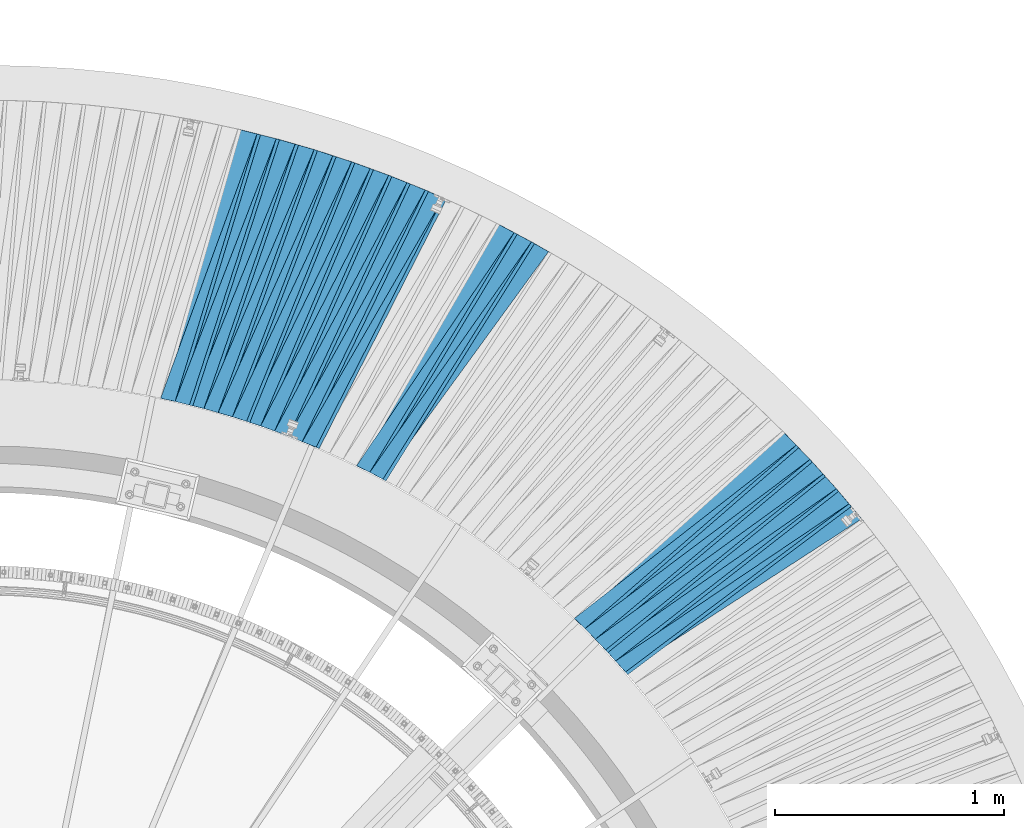
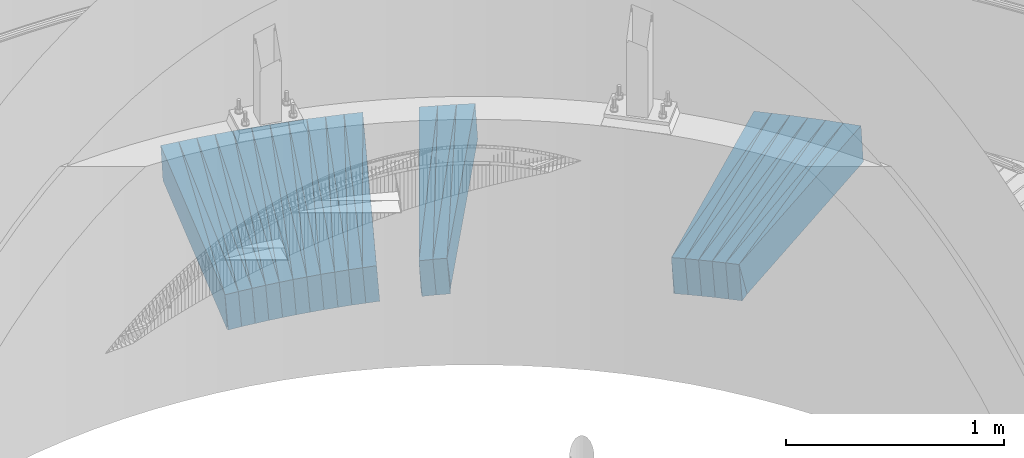
# One storey, part 840 of 975: 38 plates.
"""IFC2X3 building model written with IfcOpenShell, lengths in millimetres."""

from ifc_helpers import new_model, si_unit, frame, origin_with_axes, place, context, subcontext, project, spatial, faceted_brep, material, type_object, element, save


model = new_model("IFC2X3")

# Units and contexts
model_context = context("Model", 3, precision=1e-05, world=origin_with_axes())
body_context = subcontext(model_context, "Body", "Model", "MODEL_VIEW")
ifc_project = project(units=[si_unit("LENGTHUNIT", "METRE", prefix="MILLI"), si_unit("AREAUNIT", "SQUARE_METRE"), si_unit("VOLUMEUNIT", "CUBIC_METRE"), si_unit("MASSUNIT", "GRAM", prefix="KILO"), si_unit("TIMEUNIT", "SECOND"), si_unit("PLANEANGLEUNIT", "RADIAN"), si_unit("SOLIDANGLEUNIT", "STERADIAN"), si_unit("THERMODYNAMICTEMPERATUREUNIT", "DEGREE_CELSIUS"), si_unit("LUMINOUSINTENSITYUNIT", "LUMEN")], contexts=[model_context])

# Site, building, storey
site_placement = place(None, origin_with_axes())
site = spatial("IfcSite", under=ifc_project, at=site_placement, CompositionType="ELEMENT")
building_placement = place(site_placement, origin_with_axes())
building = spatial("IfcBuilding", under=site, at=building_placement, Name="Undefined", CompositionType="ELEMENT")
storey_placement = place(building_placement, origin_with_axes())
storey = spatial("IfcBuildingStorey", under=building, at=storey_placement, Name="Undefined", CompositionType="ELEMENT", Elevation=0.0)

# Plates
ifc_material = material(Name="STEEL/A36")
plate_type_1 = type_object("IfcPlateType", PredefinedType="NOTDEFINED")
plate_1_placement = place(storey_placement, frame((38512.4438444185, 6566.22397296083, 262.383749104979), z_axis=(0.600129765585182, -0.79788857567362, 0.0567281699704557), x_axis=(-0.799028901818095, -0.601278668863115, -0.00409590399906753)))
element("IfcPlate", 1, at=plate_1_placement, inside=storey, type_object=plate_type_1, material=ifc_material, Name="SLAB", context=body_context, shape_type="Brep", body=[
    faceted_brep([(-6.82121026329696e-12, -100.000000000011, -1.09139364212751e-10), (-4.58210372878966, -100.000000000019, 86.0459976193342), (-4.58210372927715, 99.999999999996, 86.0459976196398), (5.91171556152403e-12, 100.000000000011, 1.09139364212751e-10), (1220.7318115256, -100.000000000048, -9.56788426265121e-10), (1220.73181152511, 99.9999999999667, -6.51198206469417e-10)], [[[0, 1, 2, 3]], [[1, 4, 5, 2]], [[4, 0, 3, 5]], [[5, 3, 2]], [[4, 1, 0]]]),
])
plate_2_placement = place(storey_placement, frame((38457.2910185286, 6632.096490839, 257.390551568822), z_axis=(0.613989457399229, -0.787186763650281, 0.0579132570004221), x_axis=(-0.788357584905775, -0.615203687926472, -0.00409153799951098)))
element("IfcPlate", 2, at=plate_2_placement, inside=storey, type_object=plate_type_1, material=ifc_material, Name="SLAB", context=body_context, shape_type="Brep", body=[
    faceted_brep([(-6.82121026329696e-12, -100.000000000011, -1.09139364212751e-10), (-3.07470917727915, -99.9999999999881, 86.1187896730917), (-3.07470917695173, 99.9999999999933, 86.1187896727861), (5.91171556152403e-12, 100.000000000011, 1.09139364212751e-10), (1222.03430175661, -99.9999999999401, -9.1313268058002e-10), (1222.03430175695, 100.000000000041, -1.21872290037572e-09)], [[[0, 1, 2, 3]], [[1, 4, 5, 2]], [[4, 0, 3, 5]], [[5, 3, 2]], [[4, 1, 0]]]),
])
plate_3_placement = place(storey_placement, frame((38399.8665806011, 6696.06321003263, 252.390659540913), z_axis=(0.627521709639789, -0.776440877317488, 0.0579315799992184), x_axis=(-0.777591125053215, -0.62875692304303, -0.0040956030002803)))
element("IfcPlate", 3, at=plate_3_placement, inside=storey, type_object=plate_type_1, material=ifc_material, Name="SLAB", context=body_context, shape_type="Brep", body=[
    faceted_brep([(-6.82121026329696e-12, -100.000000000011, -1.09139364212751e-10), (-4.55440044427814, -99.9999999999895, 85.9867248536757), (-4.55440044394345, 99.9999999999973, 85.9867248534465), (5.91171556152403e-12, 100.000000000011, 1.09139364212751e-10), (1220.82153319966, -99.9999999998645, 4.24915924668312e-09), (1220.8215332, 100.000000000122, 4.01996658183634e-09)], [[[0, 1, 2, 3]], [[1, 4, 5, 2]], [[4, 0, 3, 5]], [[5, 3, 2]], [[4, 1, 0]]]),
])
plate_4_placement = place(storey_placement, frame((38342.3328437404, 6760.02912780385, 247.39052735229), z_axis=(0.641050823748855, -0.765310209783112, 0.057914800980785), x_axis=(-0.766441367156264, -0.642301761130953, -0.00400978300081753)))
element("IfcPlate", 4, at=plate_4_placement, inside=storey, type_object=plate_type_1, material=ifc_material, Name="SLAB", context=body_context, shape_type="Brep", body=[
    faceted_brep([(-6.82121026329696e-12, -100.000000000011, -1.09139364212751e-10), (-3.12398910509364, -100.000000000008, 86.1174240111322), (-3.12398910500633, 99.9999999999858, 86.1174240110013), (5.91171556152403e-12, 100.000000000011, 1.09139364212751e-10), (1222.01123047105, -100.000000000169, -5.89352566748857e-10), (1222.01123047113, 99.9999999998255, -7.20319803804159e-10)], [[[0, 1, 2, 3]], [[1, 4, 5, 2]], [[4, 0, 3, 5]], [[5, 3, 2]], [[4, 1, 0]]]),
])
plate_5_placement = place(storey_placement, frame((38282.5322403344, 6822.09727643282, 242.483601375224), z_axis=(0.654358193312262, -0.754055846141744, 0.0567021670182908), x_axis=(-0.755112156361949, -0.655582836314243, -0.00409585700196327)))
element("IfcPlate", 5, at=plate_5_placement, inside=storey, type_object=plate_type_1, material=ifc_material, Name="SLAB", context=body_context, shape_type="Brep", body=[
    faceted_brep([(-6.82121026329696e-12, -100.000000000011, -1.09139364212751e-10), (-4.59519910850213, -99.9999999999834, 86.0845184329119), (-4.59519910808012, 99.9999999999948, 86.0845184325372), (5.91171556152403e-12, 100.000000000011, 1.09139364212751e-10), (1220.74584960676, -99.9999999998415, 8.51287040859461e-10), (1220.74584960718, 100.000000000137, 4.76575223729014e-10)], [[[0, 1, 2, 3]], [[1, 4, 5, 2]], [[4, 0, 3, 5]], [[5, 3, 2]], [[4, 1, 0]]]),
])
plate_6_placement = place(storey_placement, frame((38222.9871864841, 6883.87299197705, 237.490949568583), z_axis=(0.667419123804655, -0.74242159243685, 0.0579818270094881), x_axis=(-0.743507605194825, -0.668714962175227, -0.00409150100107212)))
element("IfcPlate", 6, at=plate_6_placement, inside=storey, type_object=plate_type_1, material=ifc_material, Name="SLAB", context=body_context, shape_type="Brep", body=[
    faceted_brep([(-6.82121026329696e-12, -100.000000000011, -1.09139364212751e-10), (-3.08127689365938, -100.0, 86.0164871215857), (-3.08127689368848, 100.000000000003, 86.0164871216039), (5.91171556152403e-12, 100.000000000011, 1.09139364212751e-10), (1222.04528808264, -99.9999999998392, -1.78260961547494e-10), (1222.04528808261, 100.000000000164, -1.60071067512035e-10)], [[[0, 1, 2, 3]], [[1, 4, 5, 2]], [[4, 0, 3, 5]], [[5, 3, 2]], [[4, 1, 0]]]),
])
plate_7_placement = place(storey_placement, frame((37128.5289780376, 7710.67831532794, 158.090572427151), z_axis=(0.846231007963166, -0.529658433771036, 0.0579225750192148), x_axis=(-0.530347702982539, -0.847770744972089, -0.00400972699986798)))
element("IfcPlate", 7, at=plate_7_placement, inside=storey, type_object=plate_type_1, material=ifc_material, Name="SLAB", context=body_context, shape_type="Brep", body=[
    faceted_brep([(-6.82121026329696e-12, -100.000000000011, -1.09139364212751e-10), (-3.07681036011127, -99.9999999999825, 86.1091384890351), (-3.07681035977294, 99.9999999999834, 86.1091384884894), (5.91171556152403e-12, 100.000000000011, 1.09139364212751e-10), (1222.02844238158, -99.9999999998959, 2.1937012206763e-09), (1222.02844238191, 100.00000000007, 1.64436642080545e-09)], [[[0, 1, 2, 3]], [[1, 4, 5, 2]], [[4, 0, 3, 5]], [[5, 3, 2]], [[4, 1, 0]]]),
])
plate_8_placement = place(storey_placement, frame((37052.5827890472, 7751.13314609902, 153.184095133322), z_axis=(0.855317255811737, -0.514982910928696, 0.0567890250144053), x_axis=(-0.51561139213053, -0.856812765216909, -0.00409605500103695)))
element("IfcPlate", 8, at=plate_8_placement, inside=storey, type_object=plate_type_1, material=ifc_material, Name="SLAB", context=body_context, shape_type="Brep", body=[
    faceted_brep([(-6.82121026329696e-12, -100.000000000011, -1.09139364212751e-10), (-4.62542104727254, -99.999999999992, 85.9506607057083), (-4.62542104697059, 99.9999999999732, 85.9506607051153), (5.91171556152403e-12, 100.000000000011, 1.09139364212751e-10), (1220.68676757962, -100.000000000126, -3.31056071445346e-09), (1220.68676757992, 99.9999999998395, -3.90355126000941e-09)], [[[0, 1, 2, 3]], [[1, 4, 5, 2]], [[4, 0, 3, 5]], [[5, 3, 2]], [[4, 1, 0]]]),
])
plate_9_placement = place(storey_placement, frame((36976.8269970994, 7791.56415099977, 148.190736685674), z_axis=(0.86414602296163, -0.499893995993658, 0.0579451789978317), x_axis=(-0.50052559080456, -0.865712073661961, -0.00409126699840245)))
element("IfcPlate", 9, at=plate_9_placement, inside=storey, type_object=plate_type_1, material=ifc_material, Name="SLAB", context=body_context, shape_type="Brep", body=[
    faceted_brep([(-6.82121026329696e-12, -100.000000000011, -1.09139364212751e-10), (-3.03558087353667, -99.9999999999977, 86.0741271973347), (-3.0355808736058, 100.000000000005, 86.074127197342), (5.91171556152403e-12, 100.000000000011, 1.09139364212751e-10), (1222.11535644437, -99.9999999999347, -7.38509697839618e-10), (1222.11535644429, 100.000000000068, -7.31233740225434e-10)], [[[0, 1, 2, 3]], [[1, 4, 5, 2]], [[4, 0, 3, 5]], [[5, 3, 2]], [[4, 1, 0]]]),
])
plate_10_placement = place(storey_placement, frame((36665.2850447034, 7937.32887231506, 128.390489211694), z_axis=(0.89691949845195, -0.438385729426909, 0.0579082509798018), x_axis=(-0.438910128800132, -0.898522021590837, -0.00400943299817421)))
element("IfcPlate", 10, at=plate_10_placement, inside=storey, type_object=plate_type_1, material=ifc_material, Name="SLAB", context=body_context, shape_type="Brep", body=[
    faceted_brep([(-6.82121026329696e-12, -100.000000000011, -1.09139364212751e-10), (-3.07011246679031, -99.999999999997, 86.1309127808054), (-3.070112466914, 100.000000000006, 86.130912780889), (5.91171556152403e-12, 100.000000000011, 1.09139364212751e-10), (1222.1180419939, -99.9999999997649, 3.76167008653283e-09), (1222.11804199413, 100.000000000251, 4.22005541622639e-09)], [[[0, 1, 2, 3]], [[1, 4, 5, 2]], [[4, 0, 3, 5]], [[5, 3, 2]], [[4, 1, 0]]]),
])
plate_11_placement = place(storey_placement, frame((36585.5229821275, 7969.67831780267, 123.484010152504), z_axis=(0.904445382172855, -0.42279457464437, 0.0567740990019654), x_axis=(-0.423263062090815, -0.905997574194385, -0.00409583000087877)))
element("IfcPlate", 11, at=plate_11_placement, inside=storey, type_object=plate_type_1, material=ifc_material, Name="SLAB", context=body_context, shape_type="Brep", body=[
    faceted_brep([(-6.82121026329696e-12, -100.000000000011, -1.09139364212751e-10), (-4.58101367935888, -100.000000000025, 85.9764785762454), (-4.58101367944982, 99.9999999999959, 85.9764785765838), (5.91171556152403e-12, 100.000000000011, 1.09139364212751e-10), (1220.75378417907, -100.000000000089, -2.72848410531878e-10), (1220.75378417927, 99.9999999999472, 1.96450855582952e-10)], [[[0, 1, 2, 3]], [[1, 4, 5, 2]], [[4, 0, 3, 5]], [[5, 3, 2]], [[4, 1, 0]]]),
])
plate_12_placement = place(storey_placement, frame((36505.8602576842, 8001.92598001829, 118.490456403879), z_axis=(0.911679543641339, -0.406802610473687, 0.0578968549898234), x_axis=(-0.40726602913705, -0.913300411307339, -0.00409148100137685)))
element("IfcPlate", 12, at=plate_12_placement, inside=storey, type_object=plate_type_1, material=ifc_material, Name="SLAB", context=body_context, shape_type="Brep", body=[
    faceted_brep([(-6.82121026329696e-12, -100.000000000011, -1.09139364212751e-10), (-3.11201334011639, -99.9999999999909, 86.1405563355911), (-3.11201334000725, 99.9999999999977, 86.1405563354019), (5.91171556152403e-12, 100.000000000011, 1.09139364212751e-10), (1222.05139160054, -100.000000000137, -7.20319803804159e-10), (1222.05139160042, 99.9999999998413, -1.0986695997417e-09)], [[[0, 1, 2, 3]], [[1, 4, 5, 2]], [[4, 0, 3, 5]], [[5, 3, 2]], [[4, 1, 0]]]),
])
plate_13_placement = place(storey_placement, frame((36425.0958164199, 8031.42020133776, 113.490576521641), z_axis=(0.918576091790677, -0.390977693020075, 0.0579172439888695), x_axis=(-0.39141315420731, -0.920205936487382, -0.00409599400216941)))
element("IfcPlate", 13, at=plate_13_placement, inside=storey, type_object=plate_type_1, material=ifc_material, Name="SLAB", context=body_context, shape_type="Brep", body=[
    faceted_brep([(-6.82121026329696e-12, -100.000000000011, -1.09139364212751e-10), (-4.59260845190875, -99.9999999999848, 86.0052795412739), (-4.59260845165409, 99.9999999999777, 86.0052795406409), (5.91171556152403e-12, 100.000000000011, 1.09139364212751e-10), (1220.70495605269, -99.9999999997788, 5.34055288881063e-09), (1220.70495605294, 100.000000000184, 4.70026861876249e-09)], [[[0, 1, 2, 3]], [[1, 4, 5, 2]], [[4, 0, 3, 5]], [[5, 3, 2]], [[4, 1, 0]]]),
])
plate_14_placement = place(storey_placement, frame((36344.3303457392, 8060.91512411067, 108.490728642117), z_axis=(0.925276061863931, -0.374842268265971, 0.0579437939972551), x_axis=(-0.375249880078008, -0.92691466119269, -0.0040912550008505)))
element("IfcPlate", 14, at=plate_14_placement, inside=storey, type_object=plate_type_1, material=ifc_material, Name="SLAB", context=body_context, shape_type="Brep", body=[
    faceted_brep([(-6.82121026329696e-12, -100.000000000011, -1.09139364212751e-10), (-3.08935546864814, -100.000000000018, 86.072387694996), (-3.08935546877547, 99.9999999999975, 86.0723876952798), (5.91171556152403e-12, 100.000000000011, 1.09139364212751e-10), (1222.11901855294, -99.9999999998197, 2.76850187219679e-09), (1222.11901855281, 100.000000000196, 3.04135028272867e-09)], [[[0, 1, 2, 3]], [[1, 4, 5, 2]], [[4, 0, 3, 5]], [[5, 3, 2]], [[4, 1, 0]]]),
])
plate_15_placement = place(storey_placement, frame((36262.5538928594, 8087.60613000969, 103.490438866899), z_axis=(0.931677422065028, -0.358643075378493, 0.0578992719930006), x_axis=(-0.359025588126448, -0.933319086328715, -0.00401374700141364)))
element("IfcPlate", 15, at=plate_15_placement, inside=storey, type_object=plate_type_1, material=ifc_material, Name="SLAB", context=body_context, shape_type="Brep", body=[
    faceted_brep([(-6.82121026329696e-12, -100.000000000011, -1.09139364212751e-10), (-4.56207418437043, -100.000000000007, 86.0406188963461), (-4.56207418443228, 100.000000000003, 86.0406188965171), (5.91171556152403e-12, 100.000000000011, 1.09139364212751e-10), (1220.80432129014, -100.000000000119, -2.27737473323941e-09), (1220.80432129008, 99.9999999998913, -2.11002770811319e-09)], [[[0, 1, 2, 3]], [[1, 4, 5, 2]], [[4, 0, 3, 5]], [[5, 3, 2]], [[4, 1, 0]]]),
])
plate_16_placement = place(storey_placement, frame((36180.6764728632, 8114.34215731712, 98.5839365309009), z_axis=(0.937891885973661, -0.342251779185643, 0.0567673310014741), x_axis=(-0.342587659890399, -0.939477312699446, -0.00400926599871737)))
element("IfcPlate", 16, at=plate_16_placement, inside=storey, type_object=plate_type_1, material=ifc_material, Name="SLAB", context=body_context, shape_type="Brep", body=[
    faceted_brep([(-6.82121026329696e-12, -100.000000000011, -1.09139364212751e-10), (-3.05321955673207, -100.000000000002, 86.1016159057435), (-3.05321955678664, 99.999999999997, 86.101615905689), (5.91171556152403e-12, 100.000000000011, 1.09139364212751e-10), (1222.16894531349, -100.000000000113, -1.59707269631326e-09), (1222.16894531343, 99.9999999998859, -1.64072844199836e-09)], [[[0, 1, 2, 3]], [[1, 4, 5, 2]], [[4, 0, 3, 5]], [[5, 3, 2]], [[4, 1, 0]]]),
])
plate_17_placement = place(storey_placement, frame((36098.0020236231, 8138.14705504658, 93.6837466428715), z_axis=(0.943707008396154, -0.325881949343294, 0.0567277480268414), x_axis=(-0.326184851018973, -0.94529713205499, -0.00409574100023826)))
element("IfcPlate", 17, at=plate_17_placement, inside=storey, type_object=plate_type_1, material=ifc_material, Name="SLAB", context=body_context, shape_type="Brep", body=[
    faceted_brep([(-6.82121026329696e-12, -100.000000000011, -1.09139364212751e-10), (-4.59201431279871, -99.9999999999948, 86.0459365845709), (-4.59201431266047, 99.9999999999802, 86.0459365841416), (5.91171556152403e-12, 100.000000000011, 1.09139364212751e-10), (1220.780151366, -99.9999999997508, 3.47426976077259e-09), (1220.78015136614, 100.000000000224, 3.04498826153576e-09)], [[[0, 1, 2, 3]], [[1, 4, 5, 2]], [[4, 0, 3, 5]], [[5, 3, 2]], [[4, 1, 0]]]),
])
plate_18_placement = place(storey_placement, frame((36015.5454943625, 8161.90415118658, 88.6909269898044), z_axis=(0.949188402322483, -0.309321729144163, 0.0579779680202483), x_axis=(-0.309614424931344, -0.950853390789154, -0.00409109999909282)))
element("IfcPlate", 18, at=plate_18_placement, inside=storey, type_object=plate_type_1, material=ifc_material, Name="SLAB", context=body_context, shape_type="Brep", body=[
    faceted_brep([(-6.82121026329696e-12, -100.000000000011, -1.09139364212751e-10), (-3.05938172346941, -99.9999999999786, 86.0237731937377), (-3.0593817233239, 99.9999999999795, 86.0237731930247), (5.91171556152403e-12, 100.000000000011, 1.09139364212751e-10), (1222.16528320204, -99.9999999997847, 3.76894604414701e-09), (1222.16528320219, 100.000000000174, 3.05590219795704e-09)], [[[0, 1, 2, 3]], [[1, 4, 5, 2]], [[4, 0, 3, 5]], [[5, 3, 2]], [[4, 1, 0]]]),
])
plate_19_placement = place(storey_placement, frame((35932.1631997426, 8182.79584864631, 83.6906786950336), z_axis=(0.954412272998785, -0.292814102314087, 0.0579406130040684), x_axis=(-0.29308177605212, -0.956078952170019, -0.00401369700071376)))
element("IfcPlate", 19, at=plate_19_placement, inside=storey, type_object=plate_type_1, material=ifc_material, Name="SLAB", context=body_context, shape_type="Brep", body=[
    faceted_brep([(-6.82121026329696e-12, -100.000000000011, -1.09139364212751e-10), (-4.57664632800879, -99.9999999999891, 85.9782180787806), (-4.5766463280379, 100.000000000005, 85.9782180786897), (5.91171556152403e-12, 100.000000000011, 1.09139364212751e-10), (1220.8197021478, -99.9999999998317, 4.11091605201364e-09), (1220.81970214777, 100.000000000162, 4.01996658183634e-09)], [[[0, 1, 2, 3]], [[1, 4, 5, 2]], [[4, 0, 3, 5]], [[5, 3, 2]], [[4, 1, 0]]]),
])
plate_20_placement = place(storey_placement, frame((35848.5721833754, 8203.73600877446, 78.7838149030651), z_axis=(0.959471761441024, -0.276033518308588, 0.0567400719724678), x_axis=(-0.276253149858841, -0.961076197508912, -0.00409142699790938)))
element("IfcPlate", 20, at=plate_20_placement, inside=storey, type_object=plate_type_1, material=ifc_material, Name="SLAB", context=body_context, shape_type="Brep", body=[
    faceted_brep([(-6.82121026329696e-12, -100.000000000011, -1.09139364212751e-10), (-3.096801042484, -100.000000000013, 86.1354141233242), (-3.09680104252038, 99.9999999999841, 86.1354141232696), (5.91171556152403e-12, 100.000000000011, 1.09139364212751e-10), (1222.06750488319, -100.000000000033, -1.07320374809206e-09), (1222.06750488316, 99.9999999999643, -1.12413545139134e-09)], [[[0, 1, 2, 3]], [[1, 4, 5, 2]], [[4, 0, 3, 5]], [[5, 3, 2]], [[4, 1, 0]]]),
])
plate_type_2 = type_object("IfcPlateType", PredefinedType="NOTDEFINED")
plate_21_placement = place(storey_placement, frame((38458.4558028885, 6630.60301804417, 257.51847075747), z_axis=(0.570692163025596, -0.817590122649444, 0.0765300359808758), x_axis=(-0.819609967083482, -0.572864059058349, -0.00814074300082918)))
element("IfcPlate", 21, at=plate_21_placement, inside=storey, type_object=plate_type_2, material=ifc_material, Name="SLAB", context=body_context, shape_type="Brep", body=[
    faceted_brep([(-6.82121026329696e-12, -100.000000000011, -1.09139364212751e-10), (1220.33215331924, -99.9999999999163, 64.4767761243311), (1220.33215331929, 100.000000000081, 64.4767761242947), (5.91171556152403e-12, 100.000000000011, 1.09139364212751e-10), (1228.3891601552, -99.9999999999202, 2.33922037295997e-09), (1228.38916015524, 100.000000000077, 2.29920260608196e-09)], [[[0, 1, 2, 3]], [[1, 4, 5, 2]], [[4, 0, 3, 5]], [[5, 3, 2]], [[4, 1, 0]]]),
])
plate_22_placement = place(storey_placement, frame((38343.5550834732, 6758.56985891464, 247.519183772183), z_axis=(0.598884297602811, -0.797160722740547, 0.0766314570170567), x_axis=(-0.799113513882036, -0.601126139911261, -0.00805951899881024)))
element("IfcPlate", 22, at=plate_22_placement, inside=storey, type_object=plate_type_2, material=ifc_material, Name="SLAB", context=body_context, shape_type="Brep", body=[
    faceted_brep([(-6.82121026329696e-12, -100.000000000011, -1.09139364212751e-10), (1220.3131103502, -99.999999999864, 64.4009246843016), (1220.31311034987, 100.00000000016, 64.4009246845853), (5.91171556152403e-12, 100.000000000011, 1.09139364212751e-10), (1228.36120605317, -99.9999999998568, 5.42058842256665e-09), (1228.36120605284, 100.000000000167, 5.70435076951981e-09)], [[[0, 1, 2, 3]], [[1, 4, 5, 2]], [[4, 0, 3, 5]], [[5, 3, 2]], [[4, 1, 0]]]),
])
plate_23_placement = place(storey_placement, frame((37130.1348837981, 7709.67308884445, 158.21855476833), z_axis=(0.815947044383806, -0.573036287948293, 0.0765495490239637), x_axis=(-0.574197490704699, -0.818677153578968, -0.008059768995855)))
element("IfcPlate", 23, at=plate_23_placement, inside=storey, type_object=plate_type_2, material=ifc_material, Name="SLAB", context=body_context, shape_type="Brep", body=[
    faceted_brep([(-6.82121026329696e-12, -100.000000000011, -1.09139364212751e-10), (1220.32641601752, -100.00000000017, 64.4752197246344), (1220.32641601728, 99.999999999854, 64.4752197249036), (5.91171556152403e-12, 100.000000000011, 1.09139364212751e-10), (1228.32299804886, -100.000000000183, 2.9831426218152e-10), (1228.32299804861, 99.9999999998413, 5.67524693906307e-10)], [[[0, 1, 2, 3]], [[1, 4, 5, 2]], [[4, 0, 3, 5]], [[5, 3, 2]], [[4, 1, 0]]]),
])
plate_24_placement = place(storey_placement, frame((36666.9928510786, 7936.49406973206, 128.518933555311), z_axis=(0.871342660531583, -0.484659239669528, 0.0765988860277845), x_axis=(-0.485530384203489, -0.874182640366374, -0.00805960900337782)))
element("IfcPlate", 24, at=plate_24_placement, inside=storey, type_object=plate_type_2, material=ifc_material, Name="SLAB", context=body_context, shape_type="Brep", body=[
    faceted_brep([(-6.82121026329696e-12, -100.000000000011, -1.09139364212751e-10), (1220.41796875099, -100.000000000117, 64.4407730090061), (1220.41796875136, 99.9999999998422, 64.4407730084858), (5.91171556152403e-12, 100.000000000011, 1.09139364212751e-10), (1228.34741211036, -100.000000000119, -2.29192664846778e-10), (1228.34741211073, 99.9999999998408, -7.45785655453801e-10)], [[[0, 1, 2, 3]], [[1, 4, 5, 2]], [[4, 0, 3, 5]], [[5, 3, 2]], [[4, 1, 0]]]),
])
plate_25_placement = place(storey_placement, frame((36507.5874129866, 8001.15522147504, 118.618139753754), z_axis=(0.88770874288004, -0.454007654176572, 0.0764868469962399), x_axis=(-0.454770329004352, -0.890571540008519, -0.00814125200007788)))
element("IfcPlate", 25, at=plate_25_placement, inside=storey, type_object=plate_type_2, material=ifc_material, Name="SLAB", context=body_context, shape_type="Brep", body=[
    faceted_brep([(-6.82121026329696e-12, -100.000000000011, -1.09139364212751e-10), (1220.34680175628, -99.9999999997176, 64.5228652990118), (1220.34680175612, 100.000000000299, 64.5228652992155), (5.91171556152403e-12, 100.000000000011, 1.09139364212751e-10), (1228.31237792809, -99.9999999997021, 3.95448296330869e-09), (1228.31237792793, 100.000000000315, 4.16184775531292e-09)], [[[0, 1, 2, 3]], [[1, 4, 5, 2]], [[4, 0, 3, 5]], [[5, 3, 2]], [[4, 1, 0]]]),
])
plate_26_placement = place(storey_placement, frame((36345.9530010102, 8060.25769570632, 108.607766451147), z_axis=(0.903118441179316, -0.422767523798622, 0.075131232007898), x_axis=(-0.423401997918768, -0.9059060628262, -0.0080593729984538)))
element("IfcPlate", 26, at=plate_26_placement, inside=storey, type_object=plate_type_2, material=ifc_material, Name="SLAB", context=body_context, shape_type="Brep", body=[
    faceted_brep([(-6.82121026329696e-12, -100.000000000011, -1.09139364212751e-10), (1220.42285156251, -100.000000000033, 64.3652801508215), (1220.42285156282, 99.9999999999286, 64.3652801503631), (5.91171556152403e-12, 100.000000000011, 1.09139364212751e-10), (1228.38342285156, -100.000000000036, -9.42236511036754e-10), (1228.38342285188, 99.9999999999254, -1.39698386192322e-09)], [[[0, 1, 2, 3]], [[1, 4, 5, 2]], [[4, 0, 3, 5]], [[5, 3, 2]], [[4, 1, 0]]]),
])
plate_27_placement = place(storey_placement, frame((36182.5704147794, 8113.65094029115, 98.7190199757149), z_axis=(0.91723152842072, -0.390918413738844, 0.0766101629739603), x_axis=(-0.391488185983822, -0.92014783996198, -0.00805933299966699)))
element("IfcPlate", 27, at=plate_27_placement, inside=storey, type_object=plate_type_2, material=ifc_material, Name="SLAB", context=body_context, shape_type="Brep", body=[
    faceted_brep([(-6.82121026329696e-12, -100.000000000011, -1.09139364212751e-10), (1220.46936035035, -99.9999999998004, 64.4322891260454), (1220.46936035049, 100.000000000161, 64.4322891255542), (5.91171556152403e-12, 100.000000000011, 1.09139364212751e-10), (1228.389526366, -99.9999999998108, 2.47746356762946e-09), (1228.38952636615, 100.00000000015, 1.98269844986498e-09)], [[[0, 1, 2, 3]], [[1, 4, 5, 2]], [[4, 0, 3, 5]], [[5, 3, 2]], [[4, 1, 0]]]),
])
plate_28_placement = place(storey_placement, frame((36017.1998875075, 8161.36495163694, 88.8072130577688), z_axis=(0.93042002588228, -0.358726785871568, 0.0750577679888825), x_axis=(-0.359163794936272, -0.933239742834416, -0.00805920599857007)))
element("IfcPlate", 28, at=plate_28_placement, inside=storey, type_object=plate_type_2, material=ifc_material, Name="SLAB", context=body_context, shape_type="Brep", body=[
    faceted_brep([(-6.82121026329696e-12, -100.000000000011, -1.09139364212751e-10), (1220.46582031203, -99.99999999994, 64.4301681527213), (1220.46582031217, 100.000000000038, 64.4301681524375), (5.91171556152403e-12, 100.000000000011, 1.09139364212751e-10), (1228.40893554644, -99.9999999999527, 5.45696821063757e-10), (1228.40893554658, 100.000000000025, 2.58296495303512e-10)], [[[0, 1, 2, 3]], [[1, 4, 5, 2]], [[4, 0, 3, 5]], [[5, 3, 2]], [[4, 1, 0]]]),
])
plate_type_3 = type_object("IfcPlateType", PredefinedType="NOTDEFINED")
plate_29_placement = place(storey_placement, frame((38513.6602482838, 6564.60659109683, 262.519340628292), z_axis=(0.55634832906165, -0.827407017304733, 0.0766430979618901), x_axis=(-0.829471019035715, -0.558490402024049, -0.00814244600035062)))
element("IfcPlate", 29, at=plate_29_placement, inside=storey, type_object=plate_type_3, material=ifc_material, Name="SLAB", context=body_context, shape_type="Brep", body=[
    faceted_brep([(-6.82121026329696e-12, -100.000000000011, -1.09139364212751e-10), (1219.03869629224, -100.00000000015, 64.2713775616612), (1219.03869629186, 99.9999999998768, 64.2713775619723), (5.91171556152403e-12, 100.000000000011, 1.09139364212751e-10), (1228.13208008069, -100.000000000206, -7.91260390542448e-10), (1228.13208008037, 99.9999999998117, -5.67524693906307e-10)], [[[0, 1, 2, 3]], [[1, 4, 5, 2]], [[4, 0, 3, 5]], [[5, 3, 2]], [[4, 1, 0]]]),
])
plate_30_placement = place(storey_placement, frame((38400.966694694, 6694.70192396163, 252.507635381685), z_axis=(0.584928194038999, -0.807599494489723, 0.0751136759732759), x_axis=(-0.809504810929582, -0.587057904948932, -0.00806085099929878)))
element("IfcPlate", 30, at=plate_30_placement, inside=storey, type_object=plate_type_3, material=ifc_material, Name="SLAB", context=body_context, shape_type="Brep", body=[
    faceted_brep([(-6.82121026329696e-12, -100.000000000011, -1.09139364212751e-10), (1219.12890625186, -100.000000000133, 64.2654724105378), (1219.12890625204, 99.9999999998495, 64.265472410334), (5.91171556152403e-12, 100.000000000011, 1.09139364212751e-10), (1228.15820312688, -100.000000000132, -1.68802216649055e-09), (1228.15820312708, 99.9999999998506, -1.89902493730187e-09)], [[[0, 1, 2, 3]], [[1, 4, 5, 2]], [[4, 0, 3, 5]], [[5, 3, 2]], [[4, 1, 0]]]),
])
plate_31_placement = place(storey_placement, frame((38283.8664617717, 6820.55964346348, 242.620070186942), z_axis=(0.61278906552588, -0.786511823108526, 0.076737952034316), x_axis=(-0.788426411248418, -0.615075195193798, -0.0081423770025655)))
element("IfcPlate", 31, at=plate_31_placement, inside=storey, type_object=plate_type_3, material=ifc_material, Name="SLAB", context=body_context, shape_type="Brep", body=[
    faceted_brep([(-6.82121026329696e-12, -100.000000000011, -1.09139364212751e-10), (1219.05688476812, -100.000000000178, 64.1927642800874), (1219.0568847675, 99.9999999998561, 64.1927642804621), (5.91171556152403e-12, 100.000000000011, 1.09139364212751e-10), (1228.14257812753, -100.000000000181, -3.51792550645769e-09), (1228.14257812691, 99.9999999998536, -3.14685166813433e-09)], [[[0, 1, 2, 3]], [[1, 4, 5, 2]], [[4, 0, 3, 5]], [[5, 3, 2]], [[4, 1, 0]]]),
])
plate_32_placement = place(storey_placement, frame((37054.3118745023, 7750.09197305872, 153.319394432012), z_axis=(0.82578949640658, -0.558745439461473, 0.0766501239762431), x_axis=(-0.559856983094721, -0.828549252140184, -0.00814219000137761)))
element("IfcPlate", 32, at=plate_32_placement, inside=storey, type_object=plate_type_3, material=ifc_material, Name="SLAB", context=body_context, shape_type="Brep", body=[
    faceted_brep([(-6.82121026329696e-12, -100.000000000011, -1.09139364212751e-10), (1218.99438476806, -100.000000000342, 64.2566986044221), (1218.9943847676, 99.9999999997071, 64.256698604986), (5.91171556152403e-12, 100.000000000011, 1.09139364212751e-10), (1228.17077636954, -100.000000000336, -3.06681613437831e-09), (1228.17077636909, 99.9999999997131, -2.5029294192791e-09)], [[[0, 1, 2, 3]], [[1, 4, 5, 2]], [[4, 0, 3, 5]], [[5, 3, 2]], [[4, 1, 0]]]),
])
plate_33_placement = place(storey_placement, frame((36745.4124864299, 7901.4441596528, 133.507799914821), z_axis=(0.862845142548902, -0.49985288700717, 0.0751355530382385), x_axis=(-0.500727903125692, -0.86556721021727, -0.0080604980020233)))
element("IfcPlate", 33, at=plate_33_placement, inside=storey, type_object=plate_type_3, material=ifc_material, Name="SLAB", context=body_context, shape_type="Brep", body=[
    faceted_brep([(-6.82121026329696e-12, -100.000000000011, -1.09139364212751e-10), (1219.07556152473, -100.000000000119, 64.2353134143268), (1219.07556152479, 99.9999999998813, 64.2353134143268), (5.91171556152403e-12, 100.000000000011, 1.09139364212751e-10), (1228.21191406372, -100.000000000108, -4.69299266114831e-10), (1228.21191406378, 99.9999999998913, -4.69299266114831e-10)], [[[0, 1, 2, 3]], [[1, 4, 5, 2]], [[4, 0, 3, 5]], [[5, 3, 2]], [[4, 1, 0]]]),
])
plate_34_placement = place(storey_placement, frame((36587.355127234, 7968.82176507905, 123.619597447461), z_axis=(0.879657007522185, -0.469387108345832, 0.0766765390184864), x_axis=(-0.470204934103676, -0.882519703194583, -0.00814207700179521)))
element("IfcPlate", 34, at=plate_34_placement, inside=storey, type_object=plate_type_3, material=ifc_material, Name="SLAB", context=body_context, shape_type="Brep", body=[
    faceted_brep([(-6.82121026329696e-12, -100.000000000011, -1.09139364212751e-10), (1219.06237793166, -100.000000000281, 64.2399826015826), (1219.06237793151, 99.999999999739, 64.2399826018191), (5.91171556152403e-12, 100.000000000011, 1.09139364212751e-10), (1228.18786621291, -100.000000000277, -3.08864400722086e-09), (1228.18786621276, 99.9999999997435, -2.8521753847599e-09)], [[[0, 1, 2, 3]], [[1, 4, 5, 2]], [[4, 0, 3, 5]], [[5, 3, 2]], [[4, 1, 0]]]),
])
plate_35_placement = place(storey_placement, frame((36426.8471978951, 8030.67467177675, 113.61923388158), z_axis=(0.89548142113901, -0.438452937211858, 0.0766292779892566), x_axis=(-0.439169289009029, -0.898367434018476, -0.00814181100016745)))
element("IfcPlate", 35, at=plate_35_placement, inside=storey, type_object=plate_type_3, material=ifc_material, Name="SLAB", context=body_context, shape_type="Brep", body=[
    faceted_brep([(-6.82121026329696e-12, -100.000000000011, -1.09139364212751e-10), (1219.01196288932, -99.9999999997067, 64.270011905468), (1219.01196288925, 100.000000000312, 64.2700119056899), (5.91171556152403e-12, 100.000000000011, 1.09139364212751e-10), (1228.22790527214, -99.9999999997053, 4.39831637777388e-09), (1228.22790527206, 100.000000000312, 4.61659510619938e-09)], [[[0, 1, 2, 3]], [[1, 4, 5, 2]], [[4, 0, 3, 5]], [[5, 3, 2]], [[4, 1, 0]]]),
])
plate_36_placement = place(storey_placement, frame((36264.1929398072, 8086.97512296134, 103.607817163885), z_axis=(0.91037622916137, -0.406900622939568, 0.0751465530102151), x_axis=(-0.407492386151508, -0.913173747339525, -0.0079788720029666)))
element("IfcPlate", 36, at=plate_36_placement, inside=storey, type_object=plate_type_3, material=ifc_material, Name="SLAB", context=body_context, shape_type="Brep", body=[
    faceted_brep([(-6.82121026329696e-12, -100.000000000011, -1.09139364212751e-10), (1219.11315917828, -99.9999999996735, 64.2364501995107), (1219.11315917838, 100.000000000312, 64.2364501993325), (5.91171556152403e-12, 100.000000000011, 1.09139364212751e-10), (1228.24377441271, -99.9999999996803, 3.74711817130446e-09), (1228.24377441281, 100.000000000305, 3.56521923094988e-09)], [[[0, 1, 2, 3]], [[1, 4, 5, 2]], [[4, 0, 3, 5]], [[5, 3, 2]], [[4, 1, 0]]]),
])
plate_37_placement = place(storey_placement, frame((36099.9163198175, 8137.48591875832, 93.8194530179521), z_axis=(0.923922928162605, -0.374819964234106, 0.0766577929957618), x_axis=(-0.375333553995675, -0.926854052989314, -0.00814172599990614)))
element("IfcPlate", 37, at=plate_37_placement, inside=storey, type_object=plate_type_3, material=ifc_material, Name="SLAB", context=body_context, shape_type="Brep", body=[
    faceted_brep([(-6.82121026329696e-12, -100.000000000011, -1.09139364212751e-10), (1219.08813476536, -99.9999999999554, 64.2528381353186), (1219.0881347653, 100.000000000042, 64.252838135264), (5.91171556152403e-12, 100.000000000011, 1.09139364212751e-10), (1228.24084472622, -99.9999999999386, 2.31011654250324e-09), (1228.24084472615, 100.000000000059, 2.25554686039686e-09)], [[[0, 1, 2, 3]], [[1, 4, 5, 2]], [[4, 0, 3, 5]], [[5, 3, 2]], [[4, 1, 0]]]),
])
plate_38_placement = place(storey_placement, frame((35933.9820066163, 8182.23776144689, 83.8193071862486), z_axis=(0.936406027288784, -0.342445512520498, 0.0766473940314324), x_axis=(-0.342862689128781, -0.939350947352834, -0.0080606520030277)))
element("IfcPlate", 38, at=plate_38_placement, inside=storey, type_object=plate_type_3, material=ifc_material, Name="SLAB", context=body_context, shape_type="Brep", body=[
    faceted_brep([(-6.82121026329696e-12, -100.000000000011, -1.09139364212751e-10), (1219.12622070206, -99.9999999997231, 64.2807540928879), (1219.1262207019, 100.000000000296, 64.2807540931171), (5.91171556152403e-12, 100.000000000011, 1.09139364212751e-10), (1228.18847656135, -99.9999999997058, 4.03451849706471e-09), (1228.18847656119, 100.000000000314, 4.27098711952567e-09)], [[[0, 1, 2, 3]], [[1, 4, 5, 2]], [[4, 0, 3, 5]], [[5, 3, 2]], [[4, 1, 0]]]),
])

save(model, "model.ifc")
